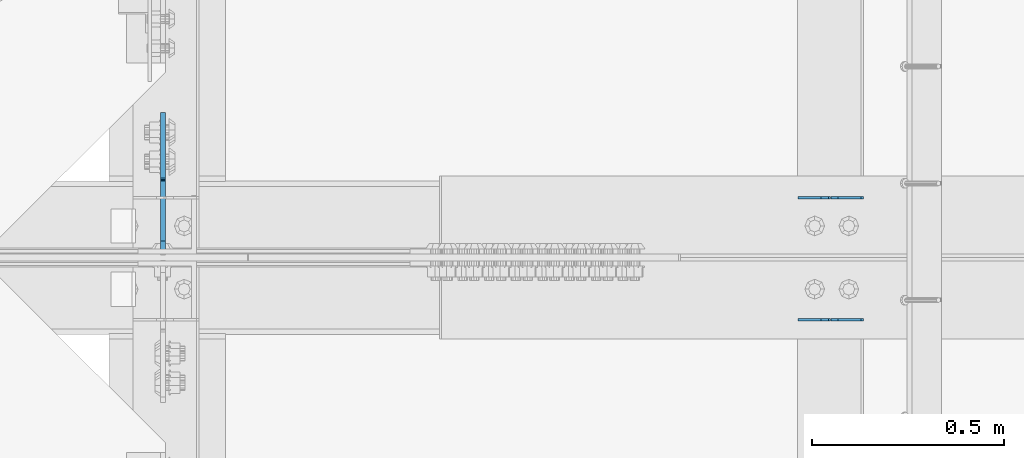
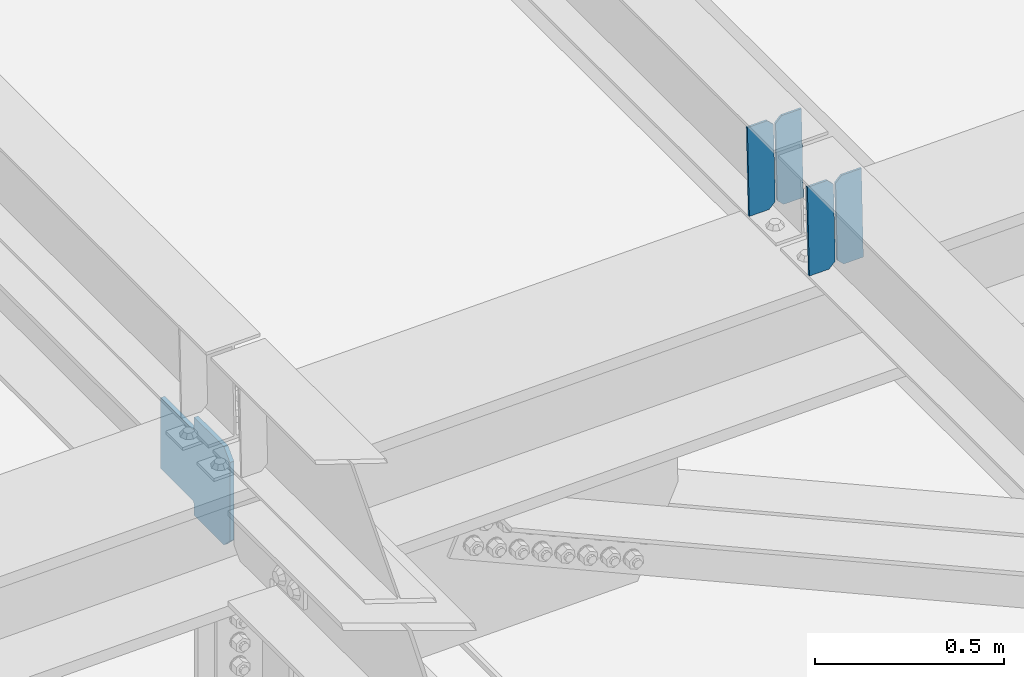
# One storey, part 3263 of 3843: 5 plates, 3 elements without a shape of their own.
"""IFC2X3 building model written with IfcOpenShell, lengths in millimetres."""

from ifc_helpers import new_model, si_unit, frame, origin_with_axes, place, context, subcontext, project, spatial, faceted_brep, material, type_object, element, aggregate, save


model = new_model("IFC2X3")

# Units and contexts
model_context = context("Model", 3, precision=1e-05, world=origin_with_axes())
body_context = subcontext(model_context, "Body", "Model", "MODEL_VIEW")
ifc_project = project(units=[si_unit("LENGTHUNIT", "METRE", prefix="MILLI"), si_unit("AREAUNIT", "SQUARE_METRE"), si_unit("VOLUMEUNIT", "CUBIC_METRE"), si_unit("MASSUNIT", "GRAM", prefix="KILO"), si_unit("TIMEUNIT", "SECOND"), si_unit("PLANEANGLEUNIT", "RADIAN"), si_unit("SOLIDANGLEUNIT", "STERADIAN"), si_unit("THERMODYNAMICTEMPERATUREUNIT", "DEGREE_CELSIUS"), si_unit("LUMINOUSINTENSITYUNIT", "LUMEN")], contexts=[model_context])

# Site, building, storey
site_placement = place(None, origin_with_axes())
site = spatial("IfcSite", under=ifc_project, at=site_placement, CompositionType="ELEMENT")
building_placement = place(site_placement, origin_with_axes())
building = spatial("IfcBuilding", under=site, at=building_placement, Name="Undefined", CompositionType="ELEMENT")
storey_placement = place(building_placement, origin_with_axes())
storey = spatial("IfcBuildingStorey", under=building, at=storey_placement, Name="Undefined", CompositionType="ELEMENT", Elevation=0.0)

# Assembly, plates
assembly_1_placement = place(storey_placement, origin_with_axes())
assembly_1 = element("IfcElementAssembly", 1, at=assembly_1_placement, inside=storey, Name="BEAM", AssemblyPlace="NOTDEFINED", PredefinedType="RIGID_FRAME")
ifc_material = material(Name="STEEL/A572-50")
plate_type_1 = type_object("IfcPlateType", PredefinedType="NOTDEFINED")
plate_1_placement = place(assembly_1_placement, frame((43878.2464781352, 50714.3069389823, 45623.1226913674), z_axis=(-0.0211520981284921, -0.000107078999957594, 0.999776263610439), x_axis=(-0.999776269342228, 3.1669999978437e-06, -0.0211520980072307)))
plate_1 = element("IfcPlate", 2, at=plate_1_placement, type_object=plate_type_1, material=ifc_material, Name="PLATE", context=body_context, shape_type="Brep", body=[
    faceted_brep([(0.0, -3.17499999999927, 0.0), (6.83940015733242e-10, -3.17499999996653, 288.924999998613), (6.54836185276508e-10, 3.17500000001746, 288.924999998591), (0.0, 3.17499999999927, 0.0), (60.3250007643655, -3.17500000017753, 288.924999998606), (60.3250007643219, 3.17499999979918, 288.924999998584), (79.3750000013097, -3.17500000025029, 269.875000761494), (79.375000001266, 3.17499999972642, 269.875000761487), (79.375000000713, -3.17500000026484, 19.0499992370605), (79.3750000006985, 3.17499999971187, 19.0499992370533), (60.325000763667, -3.17500000020664, -1.45519152283669e-11), (60.3250007636234, 3.17499999977736, -3.63797880709171e-11)], [[[0, 1, 2, 3]], [[1, 4, 5, 2]], [[4, 6, 7, 5]], [[6, 8, 9, 7]], [[8, 10, 11, 9]], [[10, 0, 3, 11]], [[5, 7, 9, 11, 3, 2]], [[10, 8, 6, 4, 1, 0]]]),
])
plate_2_placement = place(assembly_1_placement, frame((43792.5406574455, 50714.3071331025, 45621.3094277777), z_axis=(-0.0211520981284921, -0.000107078999957594, 0.999776263610439), x_axis=(-0.999776269342228, 3.1669999978437e-06, -0.0211520980072307)))
plate_2 = element("IfcPlate", 3, at=plate_2_placement, type_object=plate_type_1, material=ifc_material, Name="PLATE", context=body_context, shape_type="Brep", body=[
    faceted_brep([(4.36557456851006e-11, -3.17499999998836, 19.0499992370969), (6.11180439591408e-10, -3.17499999996653, 269.875000761516), (5.96628524363041e-10, 3.17500000001746, 269.875000761502), (1.45519152283669e-11, 3.17499999998836, 19.0499992370824), (19.0499992376572, -3.17500000003201, 288.924999998606), (19.0499992376281, 3.1749999999447, 288.924999998584), (79.3750000013242, -3.17500000025029, 288.924999998591), (79.3750000013097, 3.1749999997337, 288.92499999857), (79.3750000006548, -3.17500000026484, -2.18278728425503e-11), (79.3750000006403, 3.17499999969732, -2.91038304567337e-11), (19.0499992370023, -3.17500000005384, 0.0), (19.0499992369587, 3.17499999992287, -1.45519152283669e-11)], [[[0, 1, 2, 3]], [[1, 4, 5, 2]], [[4, 6, 7, 5]], [[6, 8, 9, 7]], [[8, 10, 11, 9]], [[10, 0, 3, 11]], [[5, 7, 9, 11, 3, 2]], [[10, 8, 6, 4, 1, 0]]]),
])
aggregate(assembly_1, [plate_1, plate_2])

assembly_2_placement = place(storey_placement, origin_with_axes())
assembly_2 = element("IfcElementAssembly", 4, at=assembly_2_placement, inside=storey, Name="BEAM", AssemblyPlace="NOTDEFINED", PredefinedType="RIGID_FRAME")
plate_3_placement = place(assembly_2_placement, frame((43878.2464782867, 50396.9814010039, 45622.9941413965), z_axis=(-0.021152098069586, -0.00069168800004991, 0.999776030076219), x_axis=(-0.99977626935017, 1.43409999980804e-05, -0.021152093007374)))
plate_3 = element("IfcPlate", 5, at=plate_3_placement, type_object=plate_type_1, material=ifc_material, Name="PLATE", context=body_context, shape_type="Brep", body=[
    faceted_brep([(0.0, -3.17499999999927, 0.0), (6.83940015733242e-10, -3.17499999996653, 288.924999998613), (6.54836185276508e-10, 3.17500000001746, 288.924999998591), (0.0, 3.17499999999927, 0.0), (60.3250007643655, -3.17500000017753, 288.924999998606), (60.3250007643219, 3.17499999979918, 288.924999998584), (79.3750000013097, -3.17500000025029, 269.875000761494), (79.375000001266, 3.17499999972642, 269.875000761487), (79.375000000713, -3.17500000026484, 19.0499992370605), (79.3750000006985, 3.17499999971187, 19.0499992370533), (60.325000763667, -3.17500000020664, -1.45519152283669e-11), (60.3250007636234, 3.17499999977736, -3.63797880709171e-11)], [[[0, 1, 2, 3]], [[1, 4, 5, 2]], [[4, 6, 7, 5]], [[6, 8, 9, 7]], [[8, 10, 11, 9]], [[10, 0, 3, 11]], [[5, 7, 9, 11, 3, 2]], [[10, 8, 6, 4, 1, 0]]]),
])
plate_4_placement = place(assembly_2_placement, frame((43792.540657597, 50396.9826554963, 45621.1808782297), z_axis=(-0.021152098069586, -0.00069168800004991, 0.999776030076219), x_axis=(-0.99977626935017, 1.43409999980804e-05, -0.021152093007374)))
plate_4 = element("IfcPlate", 6, at=plate_4_placement, type_object=plate_type_1, material=ifc_material, Name="PLATE", context=body_context, shape_type="Brep", body=[
    faceted_brep([(4.36557456851006e-11, -3.17499999998836, 19.0499992370969), (6.11180439591408e-10, -3.17499999996653, 269.875000761516), (5.96628524363041e-10, 3.17500000001746, 269.875000761502), (1.45519152283669e-11, 3.17499999998836, 19.0499992370824), (19.0499992376572, -3.17500000003201, 288.924999998606), (19.0499992376281, 3.1749999999447, 288.924999998584), (79.3750000013242, -3.17500000025029, 288.924999998591), (79.3750000013097, 3.1749999997337, 288.92499999857), (79.3750000006548, -3.17500000026484, -2.18278728425503e-11), (79.3750000006403, 3.17499999969732, -2.91038304567337e-11), (19.0499992370023, -3.17500000005384, 0.0), (19.0499992369587, 3.17499999992287, -1.45519152283669e-11)], [[[0, 1, 2, 3]], [[1, 4, 5, 2]], [[4, 6, 7, 5]], [[6, 8, 9, 7]], [[8, 10, 11, 9]], [[10, 0, 3, 11]], [[5, 7, 9, 11, 3, 2]], [[10, 8, 6, 4, 1, 0]]]),
])
aggregate(assembly_2, [plate_3, plate_4])

# Assembly, plate
assembly_3_placement = place(storey_placement, origin_with_axes())
assembly_3 = element("IfcElementAssembly", 7, at=assembly_3_placement, inside=storey, Name="BEAM", AssemblyPlace="NOTDEFINED", PredefinedType="RIGID_FRAME")
plate_type_2 = type_object("IfcPlateType", PredefinedType="NOTDEFINED")
plate_5_placement = place(assembly_3_placement, frame((42051.2874998664, 50569.8125, 45240.9647170849), z_axis=(0.0, 0.707106781186548, 0.707106781186548), x_axis=(5.70000238222118e-08, 0.707106781186546, -0.707106781186546)))
plate_5 = element("IfcPlate", 8, at=plate_5_placement, type_object=plate_type_2, material=ifc_material, Name="PLATE", context=body_context, shape_type="Brep", body=[
    faceted_brep([(0.0, -6.3499999046162, 0.0), (-179.447841212437, -6.34999999999854, 179.44784121275), (-179.447841212437, 6.34999999999854, 179.44784121275), (7.27595761418343e-12, 6.3499999046162, 0.0), (-179.447841212386, -6.34999999999854, 224.349121818348), (-179.447841212386, 6.34999999999854, 224.349121818348), (-68.3171717070836, -6.34999999999854, 335.479791324615), (-68.3171717070836, 6.34999999999854, 335.479791324615), (-46.1655519216583, -6.34999999999854, 313.328171509227), (-46.1655519216583, 6.34999999999854, 313.328171509227), (-42.045375453512, -6.34999999999854, 310.57515760875), (-42.045375453512, 6.34999999999854, 310.57515760875), (-37.1852959354437, -6.34999999999854, 309.608427686198), (-37.1852959354437, 6.34999999999854, 309.608427686198), (-32.32521641739, -6.34999999999854, 310.575157608808), (-32.32521641739, 6.34999999999854, 310.575157608808), (-28.2050399492, -6.34999999999854, 313.328171509314), (-28.2050399492, 6.34999999999854, 313.328171509314), (88.5382897707022, -6.34999999999854, 430.071501229224), (88.5382897707022, 6.34999999999854, 430.071501229224), (250.182899949155, -6.34999999999854, 268.426891050764), (250.182899949155, 6.34999999999854, 268.426891050764), (133.439570229253, -6.34999999999854, 151.683561330854), (133.439570229253, 6.34999999999854, 151.683561330854), (130.686556328743, -6.34999999999854, 147.563384862675), (130.686556328743, 6.34999999999854, 147.563384862675), (129.719826406144, -6.34999999999854, 142.703305344614), (129.719826406144, 6.34999999999854, 142.703305344614), (130.686556328685, -6.34999999999854, 137.843225826553), (130.686556328685, 6.34999999999854, 137.843225826553), (133.439570229166, -6.34999999999854, 133.723049358399), (133.439570229166, 6.34999999999854, 133.723049358399), (156.031950102829, -6.35000000000582, 111.130669497703), (156.031950102829, 6.35000000000582, 111.130669497703), (44.9012806051323, -6.35000000000582, -1.45519152283669e-11), (44.9012806051323, 6.35000000000582, -1.45519152283669e-11)], [[[0, 1, 2, 3]], [[1, 4, 5, 2]], [[4, 6, 7, 5]], [[6, 8, 9, 7]], [[8, 10, 11, 9]], [[10, 12, 13, 11]], [[12, 14, 15, 13]], [[14, 16, 17, 15]], [[16, 18, 19, 17]], [[18, 20, 21, 19]], [[20, 22, 23, 21]], [[22, 24, 25, 23]], [[24, 26, 27, 25]], [[26, 28, 29, 27]], [[28, 30, 31, 29]], [[30, 32, 33, 31]], [[32, 34, 35, 33]], [[34, 0, 3, 35]], [[5, 7, 9, 11, 13, 15, 17, 19, 21, 23, 25, 27, 29, 31, 33, 35, 3, 2]], [[34, 32, 30, 28, 26, 24, 22, 20, 18, 16, 14, 12, 10, 8, 6, 4, 1, 0]]]),
])
aggregate(assembly_3, [plate_5])

save(model, "model.ifc")
